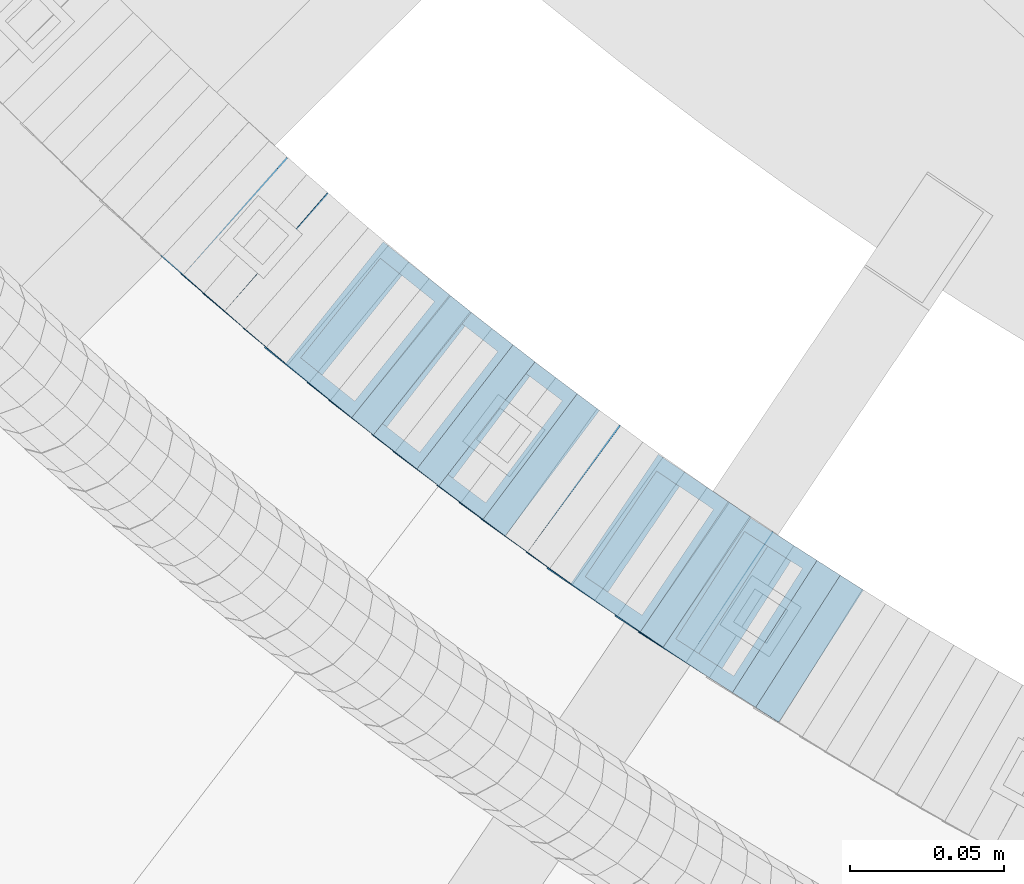
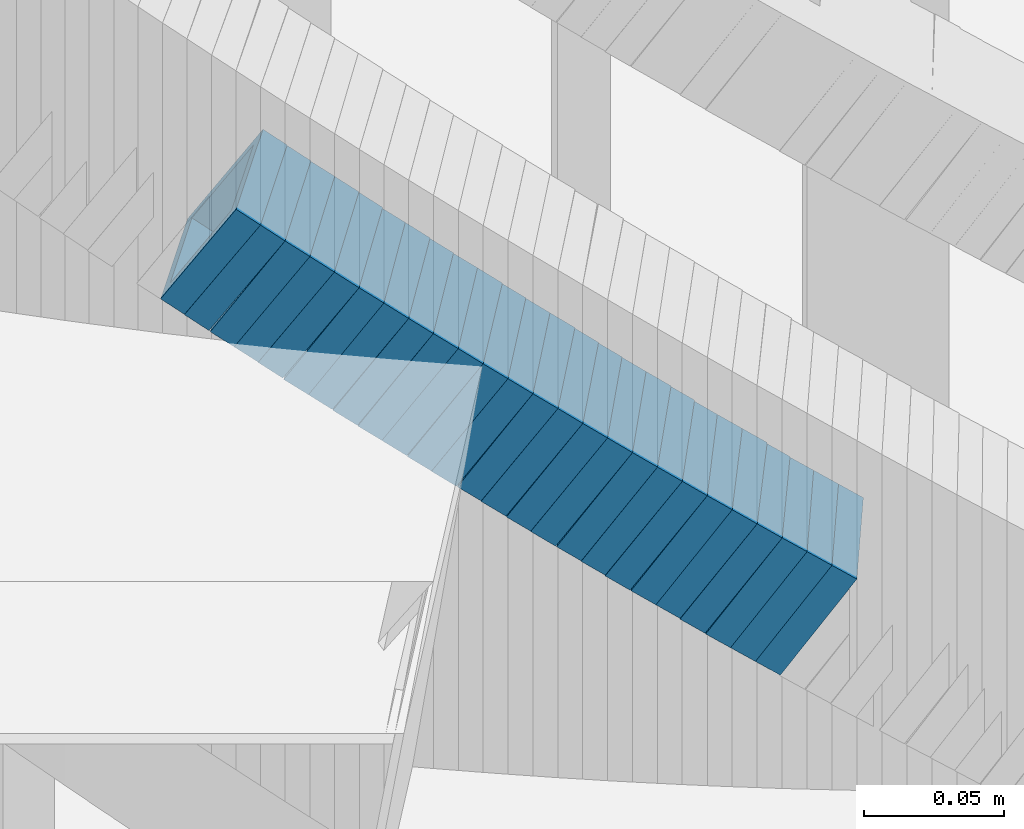
# One storey, part 732 of 975: 25 members.
"""IFC2X3 building model written with IfcOpenShell, lengths in millimetres."""

from ifc_helpers import new_model, si_unit, frame, origin_with_axes, place, context, subcontext, project, spatial, faceted_brep, material, type_object, element, save


model = new_model("IFC2X3")

# Units and contexts
model_context = context("Model", 3, precision=1e-05, world=origin_with_axes())
body_context = subcontext(model_context, "Body", "Model", "MODEL_VIEW")
ifc_project = project(units=[si_unit("LENGTHUNIT", "METRE", prefix="MILLI"), si_unit("AREAUNIT", "SQUARE_METRE"), si_unit("VOLUMEUNIT", "CUBIC_METRE"), si_unit("MASSUNIT", "GRAM", prefix="KILO"), si_unit("TIMEUNIT", "SECOND"), si_unit("PLANEANGLEUNIT", "RADIAN"), si_unit("SOLIDANGLEUNIT", "STERADIAN"), si_unit("THERMODYNAMICTEMPERATUREUNIT", "DEGREE_CELSIUS"), si_unit("LUMINOUSINTENSITYUNIT", "LUMEN")], contexts=[model_context])

# Site, building, storey
site_placement = place(None, origin_with_axes())
site = spatial("IfcSite", under=ifc_project, at=site_placement, CompositionType="ELEMENT")
building_placement = place(site_placement, origin_with_axes())
building = spatial("IfcBuilding", under=site, at=building_placement, Name="Undefined", CompositionType="ELEMENT")
storey_placement = place(building_placement, origin_with_axes())
storey = spatial("IfcBuildingStorey", under=building, at=storey_placement, Name="Undefined", CompositionType="ELEMENT", Elevation=0.0)

# Members
ifc_material = material()
member_type = type_object("IfcMemberType", Name="HSS2X2X.188_TUBES", PredefinedType="NOTDEFINED")
member_1_placement = place(storey_placement, frame((33813.0007611056, 2353.3711673536, 3941.93755765077), z_axis=(-0.65450081979011, -0.756061291757536, 0.0), x_axis=(-0.635878572879119, 0.550462048895404, 0.5409713238972)))
element("IfcMember", 1, at=member_1_placement, inside=storey, type_object=member_type, material=ifc_material, Name="WALL", ObjectType="HSS2X2X.188_TUBES", context=body_context, shape_type="Brep", body=[
    faceted_brep([(0.0, 20.6374999999753, -20.6375000000298), (0.0, -20.6375000000153, -20.6375000000153), (10.5422957651572, -20.6374999999771, -20.6374999999534), (10.5422957651481, 20.6375000000153, -20.6374999999789), (0.0, -20.6374999999825, 20.6375000000335), (10.5422957651535, -20.6374999999971, 20.6375000000298), (0.0, 20.6375000000116, 20.6375000000189), (10.5422957651444, 20.6374999999971, 20.6375000000044), (0.0, 25.3999999999724, -25.4000000000342), (0.0, 25.400000000016, 25.4000000000196), (10.5422957651426, 25.3999999999924, 25.3999999999905), (10.5422957651463, 25.4000000000178, -25.3999999999833), (0.0, -25.399999999976, 25.4000000000378), (10.5422957651499, -25.3999999999996, 25.4000000000269), (0.0, -25.400000000016, -25.4000000000196), (10.5422957651554, -25.3999999999742, -25.3999999999469)], [[[0, 1, 2, 3]], [[1, 4, 5, 2]], [[4, 6, 7, 5]], [[6, 0, 3, 7]], [[8, 9, 10, 11]], [[9, 12, 13, 10]], [[12, 14, 15, 13]], [[14, 8, 11, 15]], [[13, 15, 11, 10], [5, 7, 3, 2]], [[14, 12, 9, 8], [6, 4, 1, 0]]]),
])
member_2_placement = place(storey_placement, frame((33819.5284821583, 2347.67204631191, 3936.19328222406), z_axis=(-0.648946606014645, -0.760833952017175, 0.0), x_axis=(-0.638223397472876, 0.544367015403294, 0.544367015403294)))
element("IfcMember", 2, at=member_2_placement, inside=storey, type_object=member_type, material=ifc_material, Name="WALL", ObjectType="HSS2X2X.188_TUBES", context=body_context, shape_type="Brep", body=[
    faceted_brep([(0.0, 20.6374999999753, -20.6375000000298), (0.0, -20.6375000000153, -20.6375000000153), (10.648004507897, -20.6374999999862, -20.637499999968), (10.6480045078188, 20.6374999999771, -20.6375000000808), (0.0, -20.6374999999825, 20.6375000000335), (10.6480045079406, -20.6374999999698, 20.6375000001062), (0.0, 20.6375000000116, 20.6375000000189), (10.6480045078679, 20.6374999999935, 20.6375000000007), (0.0, 25.3999999999724, -25.4000000000342), (0.0, 25.400000000016, 25.4000000000196), (10.6480045078661, 25.3999999999905, 25.4000000000015), (10.648004507806, 25.3999999999705, -25.4000000000997), (0.0, -25.399999999976, 25.4000000000378), (10.6480045079552, -25.3999999999633, 25.4000000001288), (0.0, -25.400000000016, -25.4000000000196), (10.6480045078988, -25.3999999999814, -25.3999999999651)], [[[0, 1, 2, 3]], [[1, 4, 5, 2]], [[4, 6, 7, 5]], [[6, 0, 3, 7]], [[8, 9, 10, 11]], [[9, 12, 13, 10]], [[12, 14, 15, 13]], [[14, 8, 11, 15]], [[13, 15, 11, 10], [5, 7, 3, 2]], [[14, 12, 9, 8], [6, 4, 1, 0]]]),
])
member_3_placement = place(storey_placement, frame((33826.4171506223, 2341.75238878287, 3930.33213827412), z_axis=(-0.643452227740157, -0.765486270690878, 0.0), x_axis=(-0.646982418110182, 0.54384029309259, 0.53446373709099)))
element("IfcMember", 3, at=member_3_placement, inside=storey, type_object=member_type, material=ifc_material, Name="WALL", ObjectType="HSS2X2X.188_TUBES", context=body_context, shape_type="Brep", body=[
    faceted_brep([(0.0, 20.6374999999753, -20.6375000000298), (0.0, -20.6375000000153, -20.6375000000153), (10.6625512894789, -20.6374999999625, -20.6374999999389), (10.6625512893879, 20.6374999999789, -20.6375000000371), (0.0, -20.6374999999825, 20.6375000000335), (10.6625512894352, -20.6374999999989, 20.6375000000153), (0.0, 20.6375000000116, 20.6375000000189), (10.6625512893443, 20.6374999999443, 20.6374999999134), (0.0, 25.3999999999724, -25.4000000000342), (0.0, 25.400000000016, 25.4000000000196), (10.6625512893297, 25.3999999999342, 25.3999999998996), (10.6625512893916, 25.399999999976, -25.4000000000415), (0.0, -25.399999999976, 25.4000000000378), (10.6625512894389, -25.399999999996, 25.400000000016), (0.0, -25.400000000016, -25.4000000000196), (10.6625512894971, -25.3999999999523, -25.3999999999214)], [[[0, 1, 2, 3]], [[1, 4, 5, 2]], [[4, 6, 7, 5]], [[6, 0, 3, 7]], [[8, 9, 10, 11]], [[9, 12, 13, 10]], [[12, 14, 15, 13]], [[14, 8, 11, 15]], [[13, 15, 11, 10], [5, 7, 3, 2]], [[14, 12, 9, 8], [6, 4, 1, 0]]]),
])
member_4_placement = place(storey_placement, frame((33833.0611868849, 2336.15879181537, 3924.72961251409), z_axis=(-0.642398813105216, -0.766370514125517, 0.0), x_axis=(-0.644788773974778, 0.540484706978885, 0.540484706978885)))
element("IfcMember", 4, at=member_4_placement, inside=storey, type_object=member_type, material=ifc_material, Name="WALL", ObjectType="HSS2X2X.188_TUBES", context=body_context, shape_type="Brep", body=[
    faceted_brep([(0.0, 20.6374999999753, -20.6375000000298), (0.0, -20.6375000000153, -20.6375000000153), (10.5531985672587, -20.6374999999916, -20.6375000000007), (10.5531985672878, 20.6375000000062, -20.6374999999789), (0.0, -20.6374999999825, 20.6375000000335), (10.5531985672114, -20.6375000000353, 20.6374999999171), (0.0, 20.6375000000116, 20.6375000000189), (10.5531985672333, 20.6374999999607, 20.6374999999316), (0.0, 25.3999999999724, -25.4000000000342), (0.0, 25.400000000016, 25.4000000000196), (10.5531985672314, 25.399999999956, 25.3999999999251), (10.5531985672933, 25.4000000000106, -25.3999999999724), (0.0, -25.399999999976, 25.4000000000378), (10.5531985672023, -25.4000000000397, 25.3999999999069), (0.0, -25.400000000016, -25.4000000000196), (10.5531985672642, -25.3999999999851, -25.3999999999869)], [[[0, 1, 2, 3]], [[1, 4, 5, 2]], [[4, 6, 7, 5]], [[6, 0, 3, 7]], [[8, 9, 10, 11]], [[9, 12, 13, 10]], [[12, 14, 15, 13]], [[14, 8, 11, 15]], [[13, 15, 11, 10], [5, 7, 3, 2]], [[14, 12, 9, 8], [6, 4, 1, 0]]]),
])
member_5_placement = place(storey_placement, frame((33839.6923053146, 2330.55394773772, 3918.98460610443), z_axis=(-0.636881447137997, -0.770961751510029, 2.71175849775318e-10), x_axis=(-0.646982418110123, 0.534463737091026, 0.543840293092625)))
element("IfcMember", 5, at=member_5_placement, inside=storey, type_object=member_type, material=ifc_material, Name="WALL", ObjectType="HSS2X2X.188_TUBES", context=body_context, shape_type="Brep", body=[
    faceted_brep([(0.0, 20.6374999999753, -20.6375000000298), (0.0, -20.6375000000153, -20.6375000000153), (10.6625512894789, -20.6374999999625, -20.6374999999389), (10.6625512893879, 20.6374999999789, -20.6375000000371), (0.0, -20.6374999999825, 20.6375000000335), (10.6625512894352, -20.6374999999989, 20.6375000000153), (0.0, 20.6375000000116, 20.6375000000189), (10.6625512893443, 20.6374999999443, 20.6374999999134), (0.0, 25.3999999999724, -25.4000000000342), (0.0, 25.400000000016, 25.4000000000196), (10.6625512893297, 25.3999999999342, 25.3999999998996), (10.6625512893916, 25.399999999976, -25.4000000000415), (0.0, -25.399999999976, 25.4000000000378), (10.6625512894389, -25.399999999996, 25.400000000016), (0.0, -25.400000000016, -25.4000000000196), (10.6625512894971, -25.3999999999523, -25.3999999999214)], [[[0, 1, 2, 3]], [[1, 4, 5, 2]], [[4, 6, 7, 5]], [[6, 0, 3, 7]], [[8, 9, 10, 11]], [[9, 12, 13, 10]], [[12, 14, 15, 13]], [[14, 8, 11, 15]], [[13, 15, 11, 10], [5, 7, 3, 2]], [[14, 12, 9, 8], [6, 4, 1, 0]]]),
])
member_6_placement = place(storey_placement, frame((33846.3901753769, 2324.92184470257, 3913.16601616686), z_axis=(-0.624695048042231, -0.780868809052785, 0.0), x_axis=(-0.658942104066416, 0.527153683053111, 0.536567142054064)))
element("IfcMember", 6, at=member_6_placement, inside=storey, type_object=member_type, material=ifc_material, Name="WALL", ObjectType="HSS2X2X.188_TUBES", context=body_context, shape_type="Brep", body=[
    faceted_brep([(0.0, 20.6374999999753, -20.6375000000298), (0.0, -20.6375000000153, -20.6375000000153), (10.6216759506497, -20.637499999968, -20.6374999999534), (10.6216759506497, 20.6375000000262, -20.6374999999643), (0.0, -20.6374999999825, 20.6375000000335), (10.6216759506169, -20.6374999999935, 20.637500000008), (0.0, 20.6375000000116, 20.6375000000189), (10.6216759506242, 20.6375000000007, 20.6374999999971), (0.0, 25.3999999999724, -25.4000000000342), (0.0, 25.400000000016, 25.4000000000196), (10.6216759506169, 25.3999999999978, 25.3999999999869), (10.6216759506533, 25.4000000000269, -25.3999999999614), (0.0, -25.399999999976, 25.4000000000378), (10.6216759506242, -25.3999999999942, 25.4000000000051), (0.0, -25.400000000016, -25.4000000000196), (10.6216759506569, -25.3999999999614, -25.3999999999432)], [[[0, 1, 2, 3]], [[1, 4, 5, 2]], [[4, 6, 7, 5]], [[6, 0, 3, 7]], [[8, 9, 10, 11]], [[9, 12, 13, 10]], [[12, 14, 15, 13]], [[14, 8, 11, 15]], [[13, 15, 11, 10], [5, 7, 3, 2]], [[14, 12, 9, 8], [6, 4, 1, 0]]]),
])
member_7_placement = place(storey_placement, frame((33853.2582266857, 2319.42740365555, 3907.47440020284), z_axis=(-0.624695048042231, -0.780868809052785, 0.0), x_axis=(-0.65561006811247, 0.524488054089936, 0.543219771093169)))
element("IfcMember", 7, at=member_7_placement, inside=storey, type_object=member_type, material=ifc_material, Name="WALL", ObjectType="HSS2X2X.188_TUBES", context=body_context, shape_type="Brep", body=[
    faceted_brep([(0.0, 20.6374999999753, -20.6375000000298), (0.0, -20.6375000000153, -20.6375000000153), (10.6831643251735, -20.6375000000498, -20.6375000000953), (10.6831643252044, 20.637499999988, -20.6375000000226), (0.0, -20.6374999999825, 20.6375000000335), (10.6831643251935, -20.6375000000135, 20.637499999968), (0.0, 20.6375000000116, 20.6375000000189), (10.6831643252244, 20.6375000000226, 20.6375000000407), (0.0, 25.3999999999724, -25.4000000000342), (0.0, 25.400000000016, 25.4000000000196), (10.6831643252317, 25.4000000000306, 25.4000000000597), (10.6831643252044, 25.3999999999905, -25.4000000000196), (0.0, -25.399999999976, 25.4000000000378), (10.6831643251917, -25.400000000016, 25.3999999999614), (0.0, -25.400000000016, -25.4000000000196), (10.6831643251644, -25.400000000056, -25.4000000001179)], [[[0, 1, 2, 3]], [[1, 4, 5, 2]], [[4, 6, 7, 5]], [[6, 0, 3, 7]], [[8, 9, 10, 11]], [[9, 12, 13, 10]], [[12, 14, 15, 13]], [[14, 8, 11, 15]], [[13, 15, 11, 10], [5, 7, 3, 2]], [[14, 12, 9, 8], [6, 4, 1, 0]]]),
])
member_8_placement = place(storey_placement, frame((33860.0882215045, 2313.9083038995, 3901.70910192297), z_axis=(-0.61782155188774, -0.786318338857122, 0.0), x_axis=(-0.662206907099054, 0.520305427077837, 0.539225625080684)))
element("IfcMember", 8, at=member_8_placement, inside=storey, type_object=member_type, material=ifc_material, Name="WALL", ObjectType="HSS2X2X.188_TUBES", context=body_context, shape_type="Brep", body=[
    faceted_brep([(0.0, 20.6374999999753, -20.6375000000298), (0.0, -20.6375000000153, -20.6375000000153), (10.5744976239494, -20.6375000000207, -20.6375000000335), (10.5744976239657, 20.6375000000098, -20.637500000008), (0.0, -20.6374999999825, 20.6375000000335), (10.5744976239639, -20.6375000000244, 20.6374999999753), (0.0, 20.6375000000116, 20.6375000000189), (10.5744976239803, 20.6374999999989, 20.6374999999935), (0.0, 25.3999999999724, -25.4000000000342), (0.0, 25.400000000016, 25.4000000000196), (10.5744976239857, 25.4000000000051, 25.4000000000015), (10.5744976239675, 25.4000000000124, -25.4000000000051), (0.0, -25.399999999976, 25.4000000000378), (10.5744976239639, -25.4000000000287, 25.3999999999724), (0.0, -25.400000000016, -25.4000000000196), (10.5744976239494, -25.4000000000215, -25.4000000000378)], [[[0, 1, 2, 3]], [[1, 4, 5, 2]], [[4, 6, 7, 5]], [[6, 0, 3, 7]], [[8, 9, 10, 11]], [[9, 12, 13, 10]], [[12, 14, 15, 13]], [[14, 8, 11, 15]], [[13, 15, 11, 10], [5, 7, 3, 2]], [[14, 12, 9, 8], [6, 4, 1, 0]]]),
])
member_9_placement = place(storey_placement, frame((33867.060175931, 2308.38907284029, 3895.9545311128), z_axis=(-0.612397742104128, -0.79054981213442, 0.0), x_axis=(-0.667468953075577, 0.51705341405853, 0.535855357060665)))
element("IfcMember", 9, at=member_9_placement, inside=storey, type_object=member_type, material=ifc_material, Name="WALL", ObjectType="HSS2X2X.188_TUBES", context=body_context, shape_type="Brep", body=[
    faceted_brep([(0.0, 20.6374999999753, -20.6375000000298), (0.0, -20.6375000000153, -20.6375000000153), (10.6395488625676, -20.6374999999771, -20.6374999999716), (10.6395488625531, 20.6374999999916, -20.6375000000189), (0.0, -20.6374999999825, 20.6375000000335), (10.6395488625731, -20.6374999999844, 20.6375000000153), (0.0, 20.6375000000116, 20.6375000000189), (10.6395488625585, 20.6374999999825, 20.637499999968), (0.0, 25.3999999999724, -25.4000000000342), (0.0, 25.400000000016, 25.4000000000196), (10.6395488625567, 25.3999999999778, 25.3999999999614), (10.6395488625494, 25.3999999999887, -25.4000000000233), (0.0, -25.399999999976, 25.4000000000378), (10.6395488625749, -25.3999999999851, 25.400000000016), (0.0, -25.400000000016, -25.4000000000196), (10.6395488625658, -25.399999999976, -25.3999999999687)], [[[0, 1, 2, 3]], [[1, 4, 5, 2]], [[4, 6, 7, 5]], [[6, 0, 3, 7]], [[8, 9, 10, 11]], [[9, 12, 13, 10]], [[12, 14, 15, 13]], [[14, 8, 11, 15]], [[13, 15, 11, 10], [5, 7, 3, 2]], [[14, 12, 9, 8], [6, 4, 1, 0]]]),
])
member_10_placement = place(storey_placement, frame((33874.026622902, 2302.99252941199, 3890.26268787828), z_axis=(-0.612397742104128, -0.79054981213442, 0.0), x_axis=(-0.66410268113192, 0.514445739102164, 0.542506415107714)))
element("IfcMember", 10, at=member_10_placement, inside=storey, type_object=member_type, material=ifc_material, Name="WALL", ObjectType="HSS2X2X.188_TUBES", context=body_context, shape_type="Brep", body=[
    faceted_brep([(0.0, 20.6374999999753, -20.6375000000298), (0.0, -20.6375000000153, -20.6375000000153), (10.6906501205649, -20.6374999999844, -20.637499999968), (10.690650120574, 20.6375000000098, -20.6374999999716), (0.0, -20.6374999999825, 20.6375000000335), (10.6906501205467, -20.6374999999844, 20.637500000008), (0.0, 20.6375000000116, 20.6375000000189), (10.6906501205558, 20.637500000008, 20.6375000000007), (0.0, 25.3999999999724, -25.4000000000342), (0.0, 25.400000000016, 25.4000000000196), (10.6906501205522, 25.4000000000087, 25.3999999999978), (10.6906501205813, 25.4000000000124, -25.3999999999651), (0.0, -25.399999999976, 25.4000000000378), (10.6906501205431, -25.3999999999833, 25.4000000000051), (0.0, -25.400000000016, -25.4000000000196), (10.6906501205704, -25.3999999999833, -25.3999999999614)], [[[0, 1, 2, 3]], [[1, 4, 5, 2]], [[4, 6, 7, 5]], [[6, 0, 3, 7]], [[8, 9, 10, 11]], [[9, 12, 13, 10]], [[12, 14, 15, 13]], [[14, 8, 11, 15]], [[13, 15, 11, 10], [5, 7, 3, 2]], [[14, 12, 9, 8], [6, 4, 1, 0]]]),
])
member_11_placement = place(storey_placement, frame((33880.9555990029, 2297.57042745907, 3884.49658430275), z_axis=(-0.605367471213059, -0.795946119280134, 0.0), x_axis=(-0.670707309990836, 0.510115418993075, 0.538455163992673)))
element("IfcMember", 11, at=member_11_placement, inside=storey, type_object=member_type, material=ifc_material, Name="WALL", ObjectType="HSS2X2X.188_TUBES", context=body_context, shape_type="Brep", body=[
    faceted_brep([(0.0, 20.6374999999753, -20.6375000000298), (0.0, -20.6375000000153, -20.6375000000153), (10.5948100501191, -20.6375000000335, -20.6375000000844), (10.5948100501555, 20.6374999999971, -20.6375000000116), (0.0, -20.6374999999825, 20.6375000000335), (10.5948100501446, -20.6375000000098, 20.6374999999571), (0.0, 20.6375000000116, 20.6375000000189), (10.5948100501828, 20.6375000000189, 20.6375000000298), (0.0, 25.3999999999724, -25.4000000000342), (0.0, 25.400000000016, 25.4000000000196), (10.5948100501919, 25.4000000000251, 25.4000000000451), (10.5948100501591, 25.3999999999978, -25.4000000000051), (0.0, -25.399999999976, 25.4000000000378), (10.5948100501482, -25.4000000000106, 25.3999999999578), (0.0, -25.400000000016, -25.4000000000196), (10.5948100501118, -25.4000000000378, -25.400000000096)], [[[0, 1, 2, 3]], [[1, 4, 5, 2]], [[4, 6, 7, 5]], [[6, 0, 3, 7]], [[8, 9, 10, 11]], [[9, 12, 13, 10]], [[12, 14, 15, 13]], [[14, 8, 11, 15]], [[13, 15, 11, 10], [5, 7, 3, 2]], [[14, 12, 9, 8], [6, 4, 1, 0]]]),
])
member_12_placement = place(storey_placement, frame((33887.8978591174, 2292.24945802898, 3878.74949571587), z_axis=(-0.599999999999978, -0.800000000000017, -1.8644641386345e-14), x_axis=(-0.672456827953505, 0.504342620965087, 0.541701333962523)))
element("IfcMember", 12, at=member_12_placement, inside=storey, type_object=member_type, material=ifc_material, Name="WALL", ObjectType="HSS2X2X.188_TUBES", context=body_context, shape_type="Brep", body=[
    faceted_brep([(0.0, 20.6374999999753, -20.6375000000298), (0.0, -20.6375000000153, -20.6375000000153), (10.7093417165161, -20.637499999968, -20.6374999999534), (10.709341716436, 20.6374999999898, -20.6375000000116), (0.0, -20.6374999999825, 20.6375000000335), (10.7093417164688, -20.6374999999971, 20.6375000000153), (0.0, 20.6375000000116, 20.6375000000189), (10.7093417163924, 20.6374999999643, 20.6374999999571), (0.0, 25.3999999999724, -25.4000000000342), (0.0, 25.400000000016, 25.4000000000196), (10.7093417163815, 25.3999999999542, 25.3999999999469), (10.7093417164288, 25.3999999999869, -25.4000000000196), (0.0, -25.399999999976, 25.4000000000378), (10.7093417164724, -25.3999999999942, 25.4000000000196), (0.0, -25.400000000016, -25.4000000000196), (10.709341716527, -25.3999999999578, -25.3999999999432)], [[[0, 1, 2, 3]], [[1, 4, 5, 2]], [[4, 6, 7, 5]], [[6, 0, 3, 7]], [[8, 9, 10, 11]], [[9, 12, 13, 10]], [[12, 14, 15, 13]], [[14, 8, 11, 15]], [[13, 15, 11, 10], [5, 7, 3, 2]], [[14, 12, 9, 8], [6, 4, 1, 0]]]),
])
member_13_placement = place(storey_placement, frame((33895.2329719291, 2286.74812342023, 3872.94159548816), z_axis=(-0.599999999999978, -0.800000000000017, -1.8644641386345e-14), x_axis=(-0.675855260383085, 0.506891445287356, 0.535052081303314)))
element("IfcMember", 13, at=member_13_placement, inside=storey, type_object=member_type, material=ifc_material, Name="WALL", ObjectType="HSS2X2X.188_TUBES", context=body_context, shape_type="Brep", body=[
    faceted_brep([(0.0, 20.6374999999753, -20.6375000000298), (0.0, -20.6375000000153, -20.6375000000153), (10.648004507897, -20.6374999999862, -20.637499999968), (10.6480045078188, 20.6374999999771, -20.6375000000808), (0.0, -20.6374999999825, 20.6375000000335), (10.6480045079406, -20.6374999999698, 20.6375000001062), (0.0, 20.6375000000116, 20.6375000000189), (10.6480045078679, 20.6374999999935, 20.6375000000007), (0.0, 25.3999999999724, -25.4000000000342), (0.0, 25.400000000016, 25.4000000000196), (10.6480045078661, 25.3999999999905, 25.4000000000015), (10.648004507806, 25.3999999999705, -25.4000000000997), (0.0, -25.399999999976, 25.4000000000378), (10.6480045079552, -25.3999999999633, 25.4000000001288), (0.0, -25.400000000016, -25.4000000000196), (10.6480045078988, -25.3999999999814, -25.3999999999651)], [[[0, 1, 2, 3]], [[1, 4, 5, 2]], [[4, 6, 7, 5]], [[6, 0, 3, 7]], [[8, 9, 10, 11]], [[9, 12, 13, 10]], [[12, 14, 15, 13]], [[14, 8, 11, 15]], [[13, 15, 11, 10], [5, 7, 3, 2]], [[14, 12, 9, 8], [6, 4, 1, 0]]]),
])
member_14_placement = place(storey_placement, frame((33901.9899139426, 2281.62452245353, 3867.29130711657), z_axis=(-0.592817428097412, -0.80533688413233, 0.0), x_axis=(-0.675617177995551, 0.49732931199678, 0.544247171996454)))
element("IfcMember", 14, at=member_14_placement, inside=storey, type_object=member_type, material=ifc_material, Name="WALL", ObjectType="HSS2X2X.188_TUBES", context=body_context, shape_type="Brep", body=[
    faceted_brep([(0.0, 20.6374999999753, -20.6375000000298), (0.0, -20.6375000000153, -20.6375000000153), (10.6625512894789, -20.6374999999625, -20.6374999999389), (10.6625512893879, 20.6374999999789, -20.6375000000371), (0.0, -20.6374999999825, 20.6375000000335), (10.6625512894352, -20.6374999999989, 20.6375000000153), (0.0, 20.6375000000116, 20.6375000000189), (10.6625512893443, 20.6374999999443, 20.6374999999134), (0.0, 25.3999999999724, -25.4000000000342), (0.0, 25.400000000016, 25.4000000000196), (10.6625512893297, 25.3999999999342, 25.3999999998996), (10.6625512893916, 25.399999999976, -25.4000000000415), (0.0, -25.399999999976, 25.4000000000378), (10.6625512894389, -25.399999999996, 25.400000000016), (0.0, -25.400000000016, -25.4000000000196), (10.6625512894971, -25.3999999999523, -25.3999999999214)], [[[0, 1, 2, 3]], [[1, 4, 5, 2]], [[4, 6, 7, 5]], [[6, 0, 3, 7]], [[8, 9, 10, 11]], [[9, 12, 13, 10]], [[12, 14, 15, 13]], [[14, 8, 11, 15]], [[13, 15, 11, 10], [5, 7, 3, 2]], [[14, 12, 9, 8], [6, 4, 1, 0]]]),
])
member_15_placement = place(storey_placement, frame((33909.0149305716, 2276.39756412059, 3861.52367431757), z_axis=(-0.58549055389883, -0.81067922836054, -1.88117155630607e-10), x_axis=(-0.682257607152531, 0.492741605110134, 0.540120605120738)))
element("IfcMember", 15, at=member_15_placement, inside=storey, type_object=member_type, material=ifc_material, Name="WALL", ObjectType="HSS2X2X.188_TUBES", context=body_context, shape_type="Brep", body=[
    faceted_brep([(0.0, 20.6374999999753, -20.6375000000298), (0.0, -20.6375000000153, -20.6375000000153), (10.5531985672587, -20.6374999999916, -20.6375000000007), (10.5531985672878, 20.6375000000062, -20.6374999999789), (0.0, -20.6374999999825, 20.6375000000335), (10.5531985672114, -20.6375000000353, 20.6374999999171), (0.0, 20.6375000000116, 20.6375000000189), (10.5531985672333, 20.6374999999607, 20.6374999999316), (0.0, 25.3999999999724, -25.4000000000342), (0.0, 25.400000000016, 25.4000000000196), (10.5531985672314, 25.399999999956, 25.3999999999251), (10.5531985672933, 25.4000000000106, -25.3999999999724), (0.0, -25.399999999976, 25.4000000000378), (10.5531985672023, -25.4000000000397, 25.3999999999069), (0.0, -25.400000000016, -25.4000000000196), (10.5531985672642, -25.3999999999851, -25.3999999999869)], [[[0, 1, 2, 3]], [[1, 4, 5, 2]], [[4, 6, 7, 5]], [[6, 0, 3, 7]], [[8, 9, 10, 11]], [[9, 12, 13, 10]], [[12, 14, 15, 13]], [[14, 8, 11, 15]], [[13, 15, 11, 10], [5, 7, 3, 2]], [[14, 12, 9, 8], [6, 4, 1, 0]]]),
])
member_16_placement = place(storey_placement, frame((33916.0622715863, 2271.26817315922, 3855.77557518153), z_axis=(-0.580182279825393, -0.81448666175488, 0.0), x_axis=(-0.683797621876756, 0.48708871691219, 0.543291260902042)))
element("IfcMember", 16, at=member_16_placement, inside=storey, type_object=member_type, material=ifc_material, Name="WALL", ObjectType="HSS2X2X.188_TUBES", context=body_context, shape_type="Brep", body=[
    faceted_brep([(0.0, 20.6374999999753, -20.6375000000298), (0.0, -20.6375000000153, -20.6375000000153), (10.6831643251735, -20.6375000000498, -20.6375000000953), (10.6831643252044, 20.637499999988, -20.6375000000226), (0.0, -20.6374999999825, 20.6375000000335), (10.6831643251935, -20.6375000000135, 20.637499999968), (0.0, 20.6375000000116, 20.6375000000189), (10.6831643252244, 20.6375000000226, 20.6375000000407), (0.0, 25.3999999999724, -25.4000000000342), (0.0, 25.400000000016, 25.4000000000196), (10.6831643252317, 25.4000000000306, 25.4000000000597), (10.6831643252044, 25.3999999999905, -25.4000000000196), (0.0, -25.399999999976, 25.4000000000378), (10.6831643251917, -25.400000000016, 25.3999999999614), (0.0, -25.400000000016, -25.4000000000196), (10.6831643251644, -25.400000000056, -25.4000000001179)], [[[0, 1, 2, 3]], [[1, 4, 5, 2]], [[4, 6, 7, 5]], [[6, 0, 3, 7]], [[8, 9, 10, 11]], [[9, 12, 13, 10]], [[12, 14, 15, 13]], [[14, 8, 11, 15]], [[13, 15, 11, 10], [5, 7, 3, 2]], [[14, 12, 9, 8], [6, 4, 1, 0]]]),
])
member_17_placement = place(storey_placement, frame((33923.4999041364, 2265.97013353452, 3849.96716837123), z_axis=(-0.580182279825393, -0.81448666175488, 0.0), x_axis=(-0.687273838311968, 0.489564926222173, 0.536638476243563)))
element("IfcMember", 17, at=member_17_placement, inside=storey, type_object=member_type, material=ifc_material, Name="WALL", ObjectType="HSS2X2X.188_TUBES", context=body_context, shape_type="Brep", body=[
    faceted_brep([(0.0, 20.6374999999753, -20.6375000000298), (0.0, -20.6375000000153, -20.6375000000153), (10.6216759506497, -20.637499999968, -20.6374999999534), (10.6216759506497, 20.6375000000262, -20.6374999999643), (0.0, -20.6374999999825, 20.6375000000335), (10.6216759506169, -20.6374999999935, 20.637500000008), (0.0, 20.6375000000116, 20.6375000000189), (10.6216759506242, 20.6375000000007, 20.6374999999971), (0.0, 25.3999999999724, -25.4000000000342), (0.0, 25.400000000016, 25.4000000000196), (10.6216759506169, 25.3999999999978, 25.3999999999869), (10.6216759506533, 25.4000000000269, -25.3999999999614), (0.0, -25.399999999976, 25.4000000000378), (10.6216759506242, -25.3999999999942, 25.4000000000051), (0.0, -25.400000000016, -25.4000000000196), (10.6216759506569, -25.3999999999614, -25.3999999999432)], [[[0, 1, 2, 3]], [[1, 4, 5, 2]], [[4, 6, 7, 5]], [[6, 0, 3, 7]], [[8, 9, 10, 11]], [[9, 12, 13, 10]], [[12, 14, 15, 13]], [[14, 8, 11, 15]], [[13, 15, 11, 10], [5, 7, 3, 2]], [[14, 12, 9, 8], [6, 4, 1, 0]]]),
])
member_18_placement = place(storey_placement, frame((33930.4868433526, 2260.93806169257, 3844.30714083713), z_axis=(-0.572708438875059, -0.819759137821161, 0.0), x_axis=(-0.690432747898253, 0.482357124928926, 0.53910502192056)))
element("IfcMember", 18, at=member_18_placement, inside=storey, type_object=member_type, material=ifc_material, Name="WALL", ObjectType="HSS2X2X.188_TUBES", context=body_context, shape_type="Brep", body=[
    faceted_brep([(0.0, 20.6374999999753, -20.6375000000298), (0.0, -20.6375000000153, -20.6375000000153), (10.5744976239494, -20.6375000000207, -20.6375000000335), (10.5744976239657, 20.6375000000098, -20.637500000008), (0.0, -20.6374999999825, 20.6375000000335), (10.5744976239639, -20.6375000000244, 20.6374999999753), (0.0, 20.6375000000116, 20.6375000000189), (10.5744976239803, 20.6374999999989, 20.6374999999935), (0.0, 25.3999999999724, -25.4000000000342), (0.0, 25.400000000016, 25.4000000000196), (10.5744976239857, 25.4000000000051, 25.4000000000015), (10.5744976239675, 25.4000000000124, -25.4000000000051), (0.0, -25.399999999976, 25.4000000000378), (10.5744976239639, -25.4000000000287, 25.3999999999724), (0.0, -25.400000000016, -25.4000000000196), (10.5744976239494, -25.4000000000215, -25.4000000000378)], [[[0, 1, 2, 3]], [[1, 4, 5, 2]], [[4, 6, 7, 5]], [[6, 0, 3, 7]], [[8, 9, 10, 11]], [[9, 12, 13, 10]], [[12, 14, 15, 13]], [[14, 8, 11, 15]], [[13, 15, 11, 10], [5, 7, 3, 2]], [[14, 12, 9, 8], [6, 4, 1, 0]]]),
])
member_19_placement = place(storey_placement, frame((33937.3227130511, 2256.06528911188, 3838.59803033736), z_axis=(-0.559857410943981, -0.8285889689171, 0.0), x_axis=(-0.694904609116116, 0.469530142078463, 0.544654964090989)))
element("IfcMember", 19, at=member_19_placement, inside=storey, type_object=member_type, material=ifc_material, Name="WALL", ObjectType="HSS2X2X.188_TUBES", context=body_context, shape_type="Brep", body=[
    faceted_brep([(0.0, 20.6374999999753, -20.6375000000298), (0.0, -20.6375000000153, -20.6375000000153), (10.648004507897, -20.6374999999862, -20.637499999968), (10.6480045078188, 20.6374999999771, -20.6375000000808), (0.0, -20.6374999999825, 20.6375000000335), (10.6480045079406, -20.6374999999698, 20.6375000001062), (0.0, 20.6375000000116, 20.6375000000189), (10.6480045078679, 20.6374999999935, 20.6375000000007), (0.0, 25.3999999999724, -25.4000000000342), (0.0, 25.400000000016, 25.4000000000196), (10.6480045078661, 25.3999999999905, 25.4000000000015), (10.648004507806, 25.3999999999705, -25.4000000000997), (0.0, -25.399999999976, 25.4000000000378), (10.6480045079552, -25.3999999999633, 25.4000000001288), (0.0, -25.400000000016, -25.4000000000196), (10.6480045078988, -25.3999999999814, -25.3999999999651)], [[[0, 1, 2, 3]], [[1, 4, 5, 2]], [[4, 6, 7, 5]], [[6, 0, 3, 7]], [[8, 9, 10, 11]], [[9, 12, 13, 10]], [[12, 14, 15, 13]], [[14, 8, 11, 15]], [[13, 15, 11, 10], [5, 7, 3, 2]], [[14, 12, 9, 8], [6, 4, 1, 0]]]),
])
for number, where, z_axis, x_axis, name in (
    (20, (33944.8627899985, 2250.97064252575, 3832.7891891751), (-0.559857410943981, -0.8285889689171, 0.0), (-0.698455183967604, 0.471929177978117, 0.537999262975034), "WALL"),
    (21, (33952.2627899985, 2245.97064252575, 3827.0891891751), (-0.559857410943981, -0.8285889689171, 0.0), (-0.698455183967604, 0.471929177978117, 0.537999262975034), "WALL"),
):
    element("IfcMember", number, at=place(storey_placement, frame(where, z_axis=z_axis, x_axis=x_axis)), inside=storey, type_object=member_type, material=ifc_material, Name=name, ObjectType="HSS2X2X.188_TUBES", context=body_context, shape_type="Brep", body=[
        faceted_brep([(0.0, 20.6374999999753, -20.6375000000298), (0.0, -20.6375000000153, -20.6375000000153), (10.5948100501191, -20.6375000000335, -20.6375000000844), (10.5948100501555, 20.6374999999971, -20.6375000000116), (0.0, -20.6374999999825, 20.6375000000335), (10.5948100501446, -20.6375000000098, 20.6374999999571), (0.0, 20.6375000000116, 20.6375000000189), (10.5948100501828, 20.6375000000189, 20.6375000000298), (0.0, 25.3999999999724, -25.4000000000342), (0.0, 25.400000000016, 25.4000000000196), (10.5948100501919, 25.4000000000251, 25.4000000000451), (10.5948100501591, 25.3999999999978, -25.4000000000051), (0.0, -25.399999999976, 25.4000000000378), (10.5948100501482, -25.4000000000106, 25.3999999999578), (0.0, -25.400000000016, -25.4000000000196), (10.5948100501118, -25.4000000000378, -25.400000000096)], [[[0, 1, 2, 3]], [[1, 4, 5, 2]], [[4, 6, 7, 5]], [[6, 0, 3, 7]], [[8, 9, 10, 11]], [[9, 12, 13, 10]], [[12, 14, 15, 13]], [[14, 8, 11, 15]], [[13, 15, 11, 10], [5, 7, 3, 2]], [[14, 12, 9, 8], [6, 4, 1, 0]]]),
    ])
member_20_placement = place(storey_placement, frame((33959.2016177997, 2241.18794073258, 3821.37831945769), z_axis=(-0.546948584002515, -0.837166200021026, -6.08179107075556e-12), x_axis=(-0.702747648925252, 0.459128463951128, 0.543458181942188)))
element("IfcMember", 22, at=member_20_placement, inside=storey, type_object=member_type, material=ifc_material, Name="WALL", ObjectType="HSS2X2X.188_TUBES", context=body_context, shape_type="Brep", body=[
    faceted_brep([(0.0, 20.6374999999753, -20.6375000000298), (0.0, -20.6375000000153, -20.6375000000153), (10.6709887076922, -20.6374999999844, -20.6374999999825), (10.6709887076995, 20.6375000000171, -20.6374999999753), (0.0, -20.6374999999825, 20.6375000000335), (10.6709887076922, -20.6374999999971, 20.6375000000153), (0.0, 20.6375000000116, 20.6375000000189), (10.6709887076941, 20.6375000000025, 20.6375000000189), (0.0, 25.3999999999724, -25.4000000000342), (0.0, 25.400000000016, 25.4000000000196), (10.6709887076959, 25.3999999999996, 25.4000000000233), (10.6709887077013, 25.4000000000178, -25.3999999999724), (0.0, -25.399999999976, 25.4000000000378), (10.6709887076904, -25.3999999999978, 25.400000000016), (0.0, -25.400000000016, -25.4000000000196), (10.6709887076959, -25.3999999999796, -25.3999999999796)], [[[0, 1, 2, 3]], [[1, 4, 5, 2]], [[4, 6, 7, 5]], [[6, 0, 3, 7]], [[8, 9, 10, 11]], [[9, 12, 13, 10]], [[12, 14, 15, 13]], [[14, 8, 11, 15]], [[13, 15, 11, 10], [5, 7, 3, 2]], [[14, 12, 9, 8], [6, 4, 1, 0]]]),
])
for number, where, z_axis, x_axis, name in (
    (23, (33966.5232305708, 2236.3493599435, 3815.60753289956), (-0.539053695969341, -0.842271400952088, 0.0), (-0.709380442229691, 0.454003483147033, 0.5391291361746), "WALL"),
    (24, (33974.0232305708, 2231.5493599435, 3809.90753289956), (-0.539053695969341, -0.842271400952088, 0.0), (-0.709380442229691, 0.454003483147033, 0.5391291361746), "WALL"),
    (25, (33981.5232305708, 2226.7493599435, 3804.20753289956), (-0.539053695969341, -0.842271400952088, 0.0), (-0.709380442229691, 0.454003483147033, 0.5391291361746), "WALL"),
):
    element("IfcMember", number, at=place(storey_placement, frame(where, z_axis=z_axis, x_axis=x_axis)), inside=storey, type_object=member_type, material=ifc_material, Name=name, ObjectType="HSS2X2X.188_TUBES", context=body_context, shape_type="Brep", body=[
        faceted_brep([(0.0, 20.6374999999753, -20.6375000000298), (0.0, -20.6375000000153, -20.6375000000153), (10.5744976239494, -20.6375000000207, -20.6375000000335), (10.5744976239657, 20.6375000000098, -20.637500000008), (0.0, -20.6374999999825, 20.6375000000335), (10.5744976239639, -20.6375000000244, 20.6374999999753), (0.0, 20.6375000000116, 20.6375000000189), (10.5744976239803, 20.6374999999989, 20.6374999999935), (0.0, 25.3999999999724, -25.4000000000342), (0.0, 25.400000000016, 25.4000000000196), (10.5744976239857, 25.4000000000051, 25.4000000000015), (10.5744976239675, 25.4000000000124, -25.4000000000051), (0.0, -25.399999999976, 25.4000000000378), (10.5744976239639, -25.4000000000287, 25.3999999999724), (0.0, -25.400000000016, -25.4000000000196), (10.5744976239494, -25.4000000000215, -25.4000000000378)], [[[0, 1, 2, 3]], [[1, 4, 5, 2]], [[4, 6, 7, 5]], [[6, 0, 3, 7]], [[8, 9, 10, 11]], [[9, 12, 13, 10]], [[12, 14, 15, 13]], [[14, 8, 11, 15]], [[13, 15, 11, 10], [5, 7, 3, 2]], [[14, 12, 9, 8], [6, 4, 1, 0]]]),
    ])

save(model, "model.ifc")
